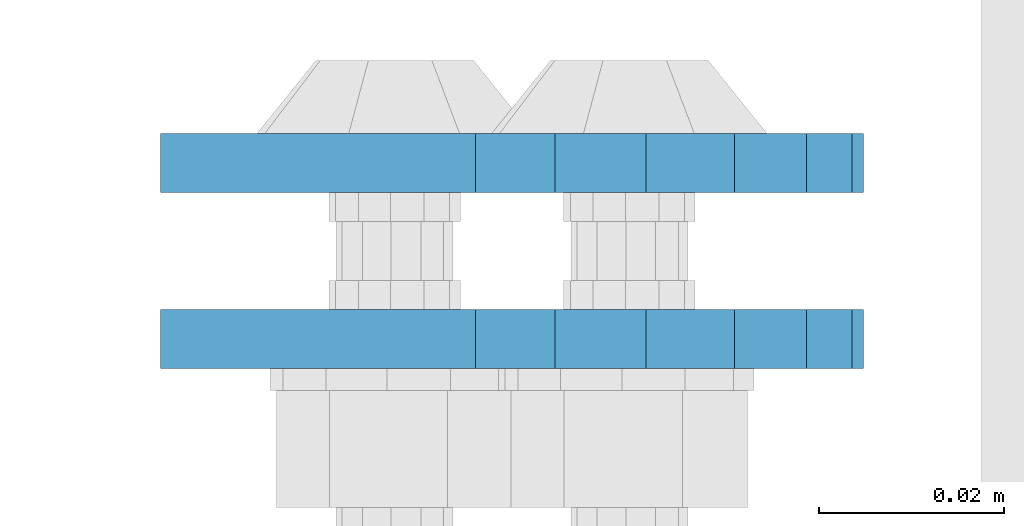
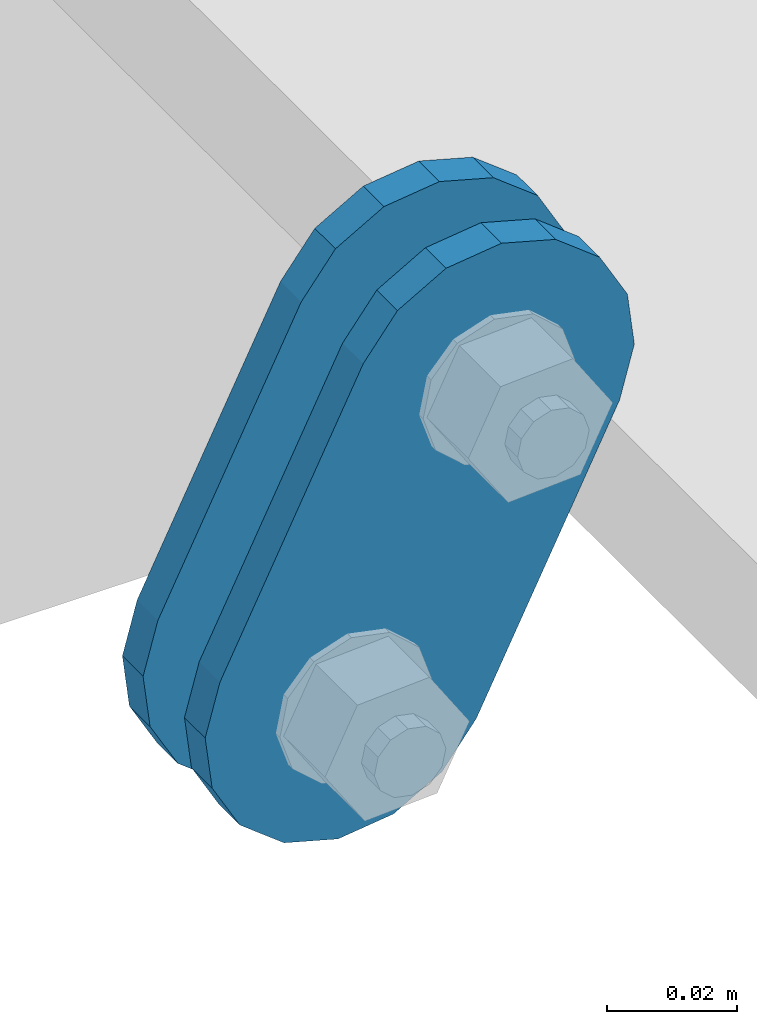
# One storey, part 1749 of 1876: 2 plates, 2 elements without a shape of their own.
"""IFC2X3 building model written with IfcOpenShell, lengths in millimetres."""

from ifc_helpers import new_model, si_unit, frame, origin_with_axes, place, context, subcontext, project, spatial, faceted_brep, material, type_object, element, aggregate, save


model = new_model("IFC2X3")

# Units and contexts
model_context = context("Model", 3, precision=1e-05, world=origin_with_axes())
body_context = subcontext(model_context, "Body", "Model", "MODEL_VIEW")
ifc_project = project(units=[si_unit("LENGTHUNIT", "METRE", prefix="MILLI"), si_unit("AREAUNIT", "SQUARE_METRE"), si_unit("VOLUMEUNIT", "CUBIC_METRE"), si_unit("MASSUNIT", "GRAM", prefix="KILO"), si_unit("TIMEUNIT", "SECOND"), si_unit("PLANEANGLEUNIT", "RADIAN"), si_unit("SOLIDANGLEUNIT", "STERADIAN"), si_unit("THERMODYNAMICTEMPERATUREUNIT", "DEGREE_CELSIUS"), si_unit("LUMINOUSINTENSITYUNIT", "LUMEN")], contexts=[model_context])

# Site, building, storey
site_placement = place(None, origin_with_axes())
site = spatial("IfcSite", under=ifc_project, at=site_placement, CompositionType="ELEMENT")
building_placement = place(site_placement, origin_with_axes())
building = spatial("IfcBuilding", under=site, at=building_placement, Name="Undefined", CompositionType="ELEMENT")
storey_placement = place(building_placement, origin_with_axes())
storey = spatial("IfcBuildingStorey", under=building, at=storey_placement, Name="Undefined", CompositionType="ELEMENT", Elevation=0.0)

# Assembly, plate
assembly_1_placement = place(storey_placement, origin_with_axes())
assembly_1 = element("IfcElementAssembly", 1, at=assembly_1_placement, inside=storey, Name="PLATE", AssemblyPlace="NOTDEFINED", PredefinedType="RIGID_FRAME")
ifc_material = material(Name="STEEL/A36")
plate_type = type_object("IfcPlateType", PredefinedType="NOTDEFINED")
plate_1_placement = place(assembly_1_placement, frame((-354.259224851122, 11674.4750022688, 7895.37767748094), z_axis=(0.894427191199916, 0.0, -0.447213595099958), x_axis=(-0.447213595099961, 6.99999707257306e-09, -0.894427191199915)))
plate_1 = element("IfcPlate", 2, at=plate_1_placement, type_object=plate_type, material=ifc_material, Name="PLATE", context=body_context, shape_type="Brep", body=[
    faceted_brep([(-8.59611645864788e-07, -3.17499999999654, 25.3999987589127), (1.93345873884391, -3.17499999999382, 35.1201580589886), (1.93345873884391, 3.17500000000564, 35.1201580589886), (-8.59611645864788e-07, 3.17500000000382, 25.3999987589132), (7.43948648259902, -3.17499999999109, 43.3605112870105), (7.43948648259902, 3.17500000000928, 43.3605112870105), (15.6798395242777, -3.17499999998654, 48.8665393096448), (15.6798395242777, 3.17500000001382, 48.8665393096448), (25.3999987589095, -3.17499999998199, 50.7999992370592), (25.3999987589095, 3.17500000001837, 50.7999992370592), (82.196130752618, -3.17499999998381, 50.7999992370605), (82.196130752618, 3.17500000001655, 50.7999992370642), (91.9162897887145, -3.17499999997926, 48.8665393918873), (91.9162897887145, 3.1750000000211, 48.8665393918909), (100.156642725027, -3.17499999997472, 43.3605115909359), (100.156642725027, 3.17500000002565, 43.3605115909395), (105.662670525982, -3.17499999997108, 35.1201586546285), (105.662670525986, 3.17500000002929, 35.1201586546358), (107.596130371159, -3.17499999996744, 25.3999996185757), (107.596130371159, 3.17500000003292, 25.3999996185794), (105.662670525981, -3.17499999996471, 15.6798405824902), (105.662670525981, 3.17500000003565, 15.6798405824939), (100.156642725024, -3.17499999996471, 7.43948764618654), (100.156642725025, 3.17500000003565, 7.43948764619017), (91.9162897887127, -3.17499999996562, 1.93345984522784), (91.9162897887127, 3.17500000003474, 1.93345984523148), (82.196130752618, -3.17499999996835, 4.54747350886464e-11), (82.196130752618, 3.1750000000311, 4.91127138957381e-11), (25.399998758905, -3.17499999999018, -8.64019966684282e-12), (25.399998758905, 3.17500000001019, -8.64019966684282e-12), (15.679839921364, -3.17499999999382, 1.9334597629304), (15.679839921364, 3.17500000000655, 1.9334597629304), (7.43948709043525, -3.17499999999654, 7.43948734220839), (7.43948709043525, 3.17500000000382, 7.43948734220885), (1.93345923228208, -3.17499999999654, 15.6798399868012), (1.93345923228208, 3.17500000000291, 15.6798399868012)], [[[0, 1, 2, 3]], [[1, 4, 5, 2]], [[4, 6, 7, 5]], [[6, 8, 9, 7]], [[8, 10, 11, 9]], [[10, 12, 13, 11]], [[12, 14, 15, 13]], [[14, 16, 17, 15]], [[16, 18, 19, 17]], [[18, 20, 21, 19]], [[20, 22, 23, 21]], [[22, 24, 25, 23]], [[24, 26, 27, 25]], [[26, 28, 29, 27]], [[28, 30, 31, 29]], [[30, 32, 33, 31]], [[32, 34, 35, 33]], [[34, 0, 3, 35]], [[5, 7, 9, 11, 13, 15, 17, 19, 21, 23, 25, 27, 29, 31, 33, 35, 3, 2]], [[34, 32, 30, 28, 26, 24, 22, 20, 18, 16, 14, 12, 10, 8, 6, 4, 1, 0]]]),
])
aggregate(assembly_1, [plate_1])

assembly_2_placement = place(storey_placement, origin_with_axes())
assembly_2 = element("IfcElementAssembly", 3, at=assembly_2_placement, inside=storey, Name="PLATE", AssemblyPlace="NOTDEFINED", PredefinedType="RIGID_FRAME")
plate_2_placement = place(assembly_2_placement, frame((-354.259224851122, 11693.5361985735, 7895.37767748094), z_axis=(0.894427191199916, 0.0, -0.447213595099958), x_axis=(-0.447213595099961, 6.99999707257306e-09, -0.894427191199915)))
plate_2 = element("IfcPlate", 4, at=plate_2_placement, type_object=plate_type, material=ifc_material, Name="PLATE", context=body_context, shape_type="Brep", body=[
    faceted_brep([(-8.59611645864788e-07, -3.17499999999654, 25.3999987589127), (1.93345873884391, -3.17499999999382, 35.1201580589886), (1.93345873884391, 3.17500000000564, 35.1201580589886), (-8.59611645864788e-07, 3.17500000000382, 25.3999987589132), (7.43948648259902, -3.17499999999109, 43.3605112870105), (7.43948648259902, 3.17500000000928, 43.3605112870105), (15.6798395242777, -3.17499999998654, 48.8665393096448), (15.6798395242777, 3.17500000001382, 48.8665393096448), (25.3999987589095, -3.17499999998199, 50.7999992370592), (25.3999987589095, 3.17500000001837, 50.7999992370592), (82.196130752618, -3.17499999998381, 50.7999992370605), (82.196130752618, 3.17500000001655, 50.7999992370642), (91.9162897887145, -3.17499999997926, 48.8665393918873), (91.9162897887145, 3.1750000000211, 48.8665393918909), (100.156642725027, -3.17499999997472, 43.3605115909359), (100.156642725027, 3.17500000002565, 43.3605115909395), (105.662670525982, -3.17499999997108, 35.1201586546285), (105.662670525986, 3.17500000002929, 35.1201586546358), (107.596130371159, -3.17499999996744, 25.3999996185757), (107.596130371159, 3.17500000003292, 25.3999996185794), (105.662670525981, -3.17499999996471, 15.6798405824902), (105.662670525981, 3.17500000003565, 15.6798405824939), (100.156642725024, -3.17499999996471, 7.43948764618654), (100.156642725025, 3.17500000003565, 7.43948764619017), (91.9162897887127, -3.17499999996562, 1.93345984522784), (91.9162897887127, 3.17500000003474, 1.93345984523148), (82.196130752618, -3.17499999996835, 4.54747350886464e-11), (82.196130752618, 3.1750000000311, 4.91127138957381e-11), (25.399998758905, -3.17499999999018, -8.64019966684282e-12), (25.399998758905, 3.17500000001019, -8.64019966684282e-12), (15.679839921364, -3.17499999999382, 1.9334597629304), (15.679839921364, 3.17500000000655, 1.9334597629304), (7.43948709043525, -3.17499999999654, 7.43948734220839), (7.43948709043525, 3.17500000000382, 7.43948734220885), (1.93345923228208, -3.17499999999654, 15.6798399868012), (1.93345923228208, 3.17500000000291, 15.6798399868012)], [[[0, 1, 2, 3]], [[1, 4, 5, 2]], [[4, 6, 7, 5]], [[6, 8, 9, 7]], [[8, 10, 11, 9]], [[10, 12, 13, 11]], [[12, 14, 15, 13]], [[14, 16, 17, 15]], [[16, 18, 19, 17]], [[18, 20, 21, 19]], [[20, 22, 23, 21]], [[22, 24, 25, 23]], [[24, 26, 27, 25]], [[26, 28, 29, 27]], [[28, 30, 31, 29]], [[30, 32, 33, 31]], [[32, 34, 35, 33]], [[34, 0, 3, 35]], [[5, 7, 9, 11, 13, 15, 17, 19, 21, 23, 25, 27, 29, 31, 33, 35, 3, 2]], [[34, 32, 30, 28, 26, 24, 22, 20, 18, 16, 14, 12, 10, 8, 6, 4, 1, 0]]]),
])
aggregate(assembly_2, [plate_2])

save(model, "model.ifc")
